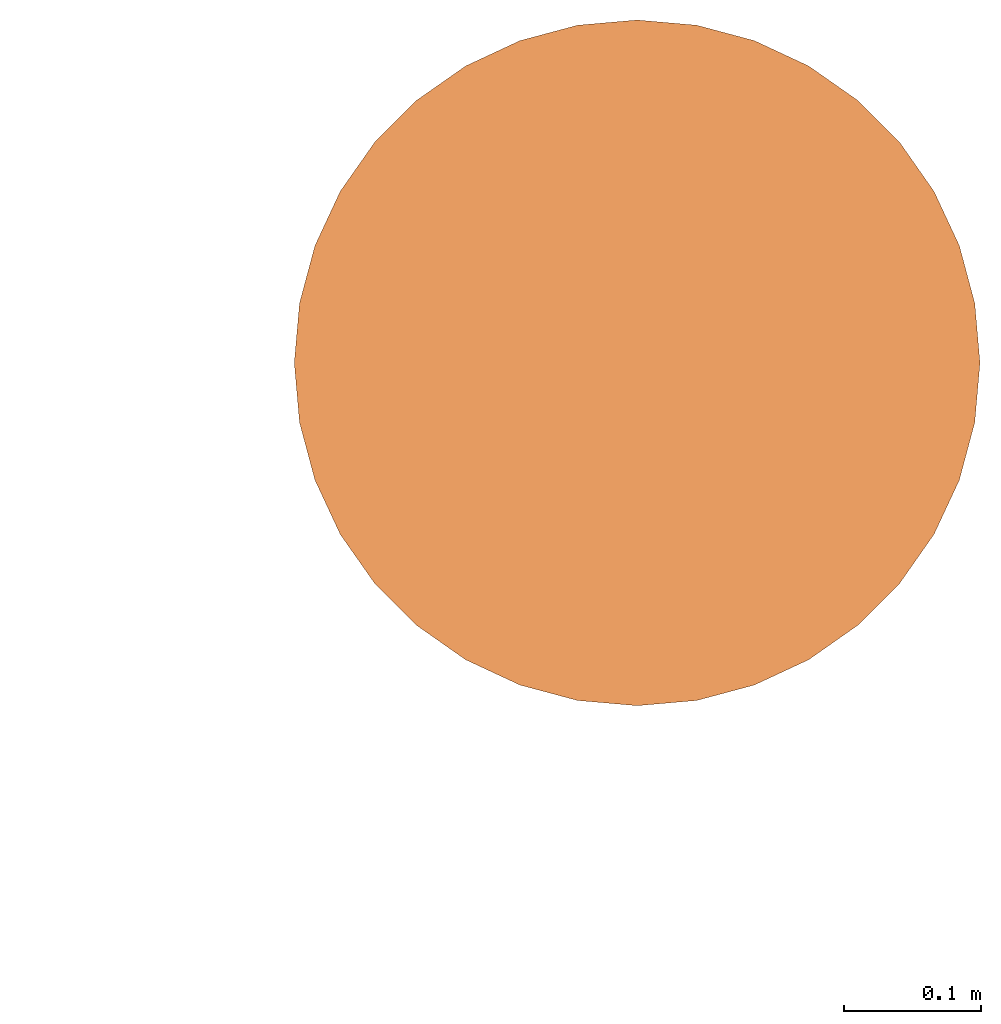
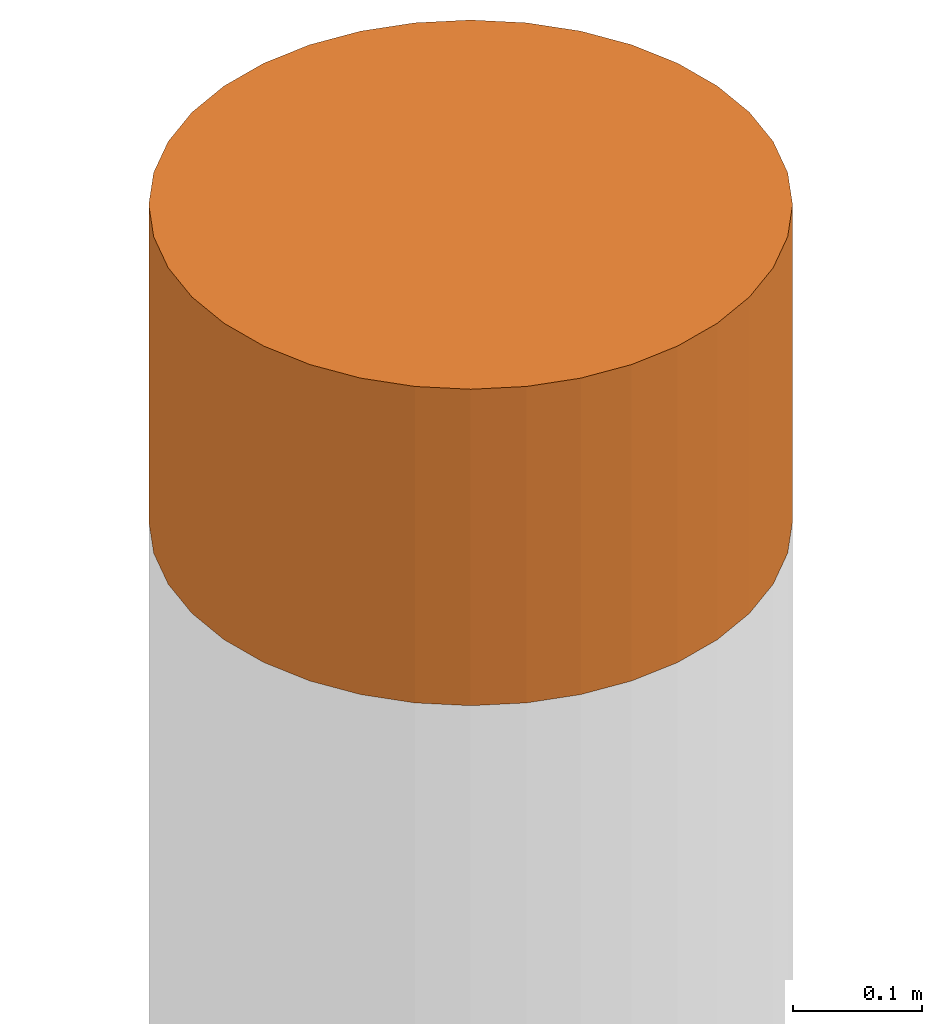
# One storey, part 8 of 8: 1 proxy.
"""IFC4 building model written with IfcOpenShell, lengths in metres."""

from ifc_helpers import new_model, entity, si_unit, converted_unit, frame, origin, place, context, subcontext, project, spatial, faceted_brep, material, element, save


model = new_model("IFC4")

# Units and contexts
model_context = context("Model", 3, precision=1e-05, world=origin())
body_context = subcontext(model_context, "Body", "Model", "MODEL_VIEW")
ifc_project = project(units=[si_unit("LENGTHUNIT", "METRE"), si_unit("AREAUNIT", "SQUARE_METRE"), si_unit("VOLUMEUNIT", "CUBIC_METRE"), converted_unit("PLANEANGLEUNIT", "DEGREE", entity("IfcPlaneAngleMeasure", 0.0174532925199433), si_unit("PLANEANGLEUNIT", "RADIAN"), dimensions=[0, 0, 0, 0, 0, 0, 0])], contexts=[model_context])

# Site, building, storey
site_placement = place(None, origin())
site = spatial("IfcSite", under=ifc_project, at=site_placement, CompositionType="ELEMENT")
building_placement = place(site_placement, origin())
building = spatial("IfcBuilding", under=site, at=building_placement, Name="Demo", CompositionType="ELEMENT")
storey_placement = place(building_placement, origin())
storey = spatial("IfcBuildingStorey", under=building, at=storey_placement, Name="Boden", CompositionType="ELEMENT", Elevation=0.0)

# Proxy
ifc_material = material()
proxy_placement = place(storey_placement, frame((15.9, 13.51, -0.09999999999999999)))
element("IfcBuildingElementProxy", 1, at=proxy_placement, inside=storey, material=ifc_material, Name="KB-03", PredefinedType="USERDEFINED", context=body_context, shape_type="Brep", body=[
    faceted_brep([(0.4962019382530489, 0.2934120444167329, 0.3), (0.5, 0.25, 0.3), (0.4962019382530489, 0.2065879555832671, 0.3), (0.4849231551964767, 0.1644949641685835, 0.3), (0.466506350946107, 0.125, 0.3), (0.441511110779742, 0.08930309757836585, 0.3), (0.4106969024216323, 0.05848888922025617, 0.3), (0.3749999999999982, 0.0334936490538912, 0.3), (0.3355050358314147, 0.01507684480352327, 0.3), (0.2934120444167311, 0.003798061746947497, 0.3), (0.2499999999999982, 0.0, 0.3), (0.2065879555832653, 0.003798061746947497, 0.3), (0.1644949641685816, 0.01507684480352327, 0.3), (0.1249999999999982, 0.03349364905388939, 0.3), (0.08930309757836404, 0.05848888922025617, 0.3), (0.05848888922025435, 0.08930309757836585, 0.3), (0.03349364905388939, 0.125, 0.3), (0.01507684480352145, 0.1644949641685835, 0.3), (0.003798061746945677, 0.2065879555832671, 0.3), (-1.818989403545857e-15, 0.25, 0.3), (0.003798061746945677, 0.2934120444167329, 0.3), (0.01507684480352145, 0.3355050358314166, 0.3), (0.03349364905388757, 0.375, 0.3), (0.05848888922025253, 0.4106969024216342, 0.3), (0.08930309757836222, 0.4415111107797439, 0.3), (0.1249999999999982, 0.4665063509461088, 0.3), (0.1644949641685798, 0.4849231551964767, 0.3), (0.2065879555832653, 0.4962019382530525, 0.3), (0.2499999999999982, 0.5, 0.3), (0.2934120444167293, 0.4962019382530525, 0.3), (0.3355050358314147, 0.4849231551964767, 0.3), (0.3749999999999982, 0.4665063509461107, 0.3), (0.4106969024216323, 0.4415111107797456, 0.3), (0.441511110779742, 0.410696902421636, 0.3), (0.466506350946107, 0.375, 0.3), (0.4849231551964767, 0.3355050358314184, 0.3), (0.5, 0.25, -1.4210854715202e-17), (0.4962019382530489, 0.2934120444167329, -1.4210854715202e-17), (0.4849231551964767, 0.3355050358314184, -1.4210854715202e-17), (0.466506350946107, 0.375, -1.4210854715202e-17), (0.441511110779742, 0.410696902421636, -1.4210854715202e-17), (0.4106969024216323, 0.4415111107797456, -1.4210854715202e-17), (0.3749999999999982, 0.4665063509461107, -1.4210854715202e-17), (0.3355050358314147, 0.4849231551964767, -1.4210854715202e-17), (0.2934120444167293, 0.4962019382530525, -1.4210854715202e-17), (0.2499999999999982, 0.5, -1.4210854715202e-17), (0.2065879555832653, 0.4962019382530525, -1.4210854715202e-17), (0.1644949641685798, 0.4849231551964767, -1.4210854715202e-17), (0.1249999999999982, 0.4665063509461088, -1.4210854715202e-17), (0.08930309757836222, 0.4415111107797439, -1.4210854715202e-17), (0.05848888922025253, 0.4106969024216342, -1.4210854715202e-17), (0.03349364905388757, 0.375, -1.4210854715202e-17), (0.01507684480352145, 0.3355050358314166, -1.4210854715202e-17), (0.003798061746945677, 0.2934120444167329, -1.4210854715202e-17), (-1.818989403545857e-15, 0.25, -1.4210854715202e-17), (0.003798061746945677, 0.2065879555832671, -1.4210854715202e-17), (0.01507684480352145, 0.1644949641685816, -1.4210854715202e-17), (0.03349364905388939, 0.125, -1.4210854715202e-17), (0.05848888922025435, 0.08930309757836585, -1.4210854715202e-17), (0.08930309757836404, 0.05848888922025617, -1.4210854715202e-17), (0.1249999999999982, 0.03349364905388939, -1.4210854715202e-17), (0.1644949641685816, 0.01507684480352327, -1.4210854715202e-17), (0.2065879555832653, 0.003798061746947497, -1.4210854715202e-17), (0.2499999999999982, 0.0, -1.4210854715202e-17), (0.2934120444167311, 0.003798061746947497, -1.4210854715202e-17), (0.3355050358314147, 0.01507684480352327, -1.4210854715202e-17), (0.3749999999999982, 0.0334936490538912, -1.4210854715202e-17), (0.4106969024216323, 0.05848888922025617, -1.4210854715202e-17), (0.441511110779742, 0.08930309757836585, -1.4210854715202e-17), (0.466506350946107, 0.125, -1.4210854715202e-17), (0.4849231551964767, 0.1644949641685835, -1.4210854715202e-17), (0.4962019382530489, 0.2065879555832671, -1.4210854715202e-17), (0.5, 0.25, 0.3), (0.4962019382530489, 0.2934120444167329, 0.3), (0.4962019382530489, 0.2934120444167329, -1.4210854715202e-17), (0.5, 0.25, -1.4210854715202e-17), (0.4962019382530489, 0.2065879555832671, 0.3), (0.5, 0.25, 0.3), (0.5, 0.25, -1.4210854715202e-17), (0.4962019382530489, 0.2065879555832671, -1.4210854715202e-17), (0.4849231551964767, 0.1644949641685835, 0.3), (0.4962019382530489, 0.2065879555832671, 0.3), (0.4962019382530489, 0.2065879555832671, -1.4210854715202e-17), (0.4849231551964767, 0.1644949641685835, -1.4210854715202e-17), (0.466506350946107, 0.125, 0.3), (0.4849231551964767, 0.1644949641685835, 0.3), (0.4849231551964767, 0.1644949641685835, -1.4210854715202e-17), (0.466506350946107, 0.125, -1.4210854715202e-17), (0.441511110779742, 0.08930309757836585, 0.3), (0.466506350946107, 0.125, 0.3), (0.466506350946107, 0.125, -1.4210854715202e-17), (0.441511110779742, 0.08930309757836585, -1.4210854715202e-17), (0.4106969024216323, 0.05848888922025617, 0.3), (0.441511110779742, 0.08930309757836585, 0.3), (0.441511110779742, 0.08930309757836585, -1.4210854715202e-17), (0.4106969024216323, 0.05848888922025617, -1.4210854715202e-17), (0.3749999999999982, 0.0334936490538912, 0.3), (0.4106969024216323, 0.05848888922025617, 0.3), (0.4106969024216323, 0.05848888922025617, -1.4210854715202e-17), (0.3749999999999982, 0.0334936490538912, -1.4210854715202e-17), (0.3355050358314147, 0.01507684480352327, 0.3), (0.3749999999999982, 0.0334936490538912, 0.3), (0.3749999999999982, 0.0334936490538912, -1.4210854715202e-17), (0.3355050358314147, 0.01507684480352327, -1.4210854715202e-17), (0.2934120444167311, 0.003798061746947497, 0.3), (0.3355050358314147, 0.01507684480352327, 0.3), (0.3355050358314147, 0.01507684480352327, -1.4210854715202e-17), (0.2934120444167311, 0.003798061746947497, -1.4210854715202e-17), (0.2499999999999982, 0.0, 0.3), (0.2934120444167311, 0.003798061746947497, 0.3), (0.2934120444167311, 0.003798061746947497, -1.4210854715202e-17), (0.2499999999999982, 0.0, -1.4210854715202e-17), (0.2065879555832653, 0.003798061746947497, 0.3), (0.2499999999999982, 0.0, 0.3), (0.2499999999999982, 0.0, -1.4210854715202e-17), (0.2065879555832653, 0.003798061746947497, -1.4210854715202e-17), (0.1644949641685816, 0.01507684480352327, 0.3), (0.2065879555832653, 0.003798061746947497, 0.3), (0.2065879555832653, 0.003798061746947497, -1.4210854715202e-17), (0.1644949641685816, 0.01507684480352327, -1.4210854715202e-17), (0.1249999999999982, 0.03349364905388939, 0.3), (0.1644949641685816, 0.01507684480352327, 0.3), (0.1644949641685816, 0.01507684480352327, -1.4210854715202e-17), (0.1249999999999982, 0.03349364905388939, -1.4210854715202e-17), (0.08930309757836404, 0.05848888922025617, 0.3), (0.1249999999999982, 0.03349364905388939, 0.3), (0.1249999999999982, 0.03349364905388939, -1.4210854715202e-17), (0.08930309757836404, 0.05848888922025617, -1.4210854715202e-17), (0.05848888922025435, 0.08930309757836585, 0.3), (0.08930309757836404, 0.05848888922025617, 0.3), (0.08930309757836404, 0.05848888922025617, -1.4210854715202e-17), (0.05848888922025435, 0.08930309757836585, -1.4210854715202e-17), (0.03349364905388939, 0.125, 0.3), (0.05848888922025435, 0.08930309757836585, 0.3), (0.05848888922025435, 0.08930309757836585, -1.4210854715202e-17), (0.03349364905388939, 0.125, -1.4210854715202e-17), (0.01507684480352145, 0.1644949641685835, 0.3), (0.03349364905388939, 0.125, 0.3), (0.03349364905388939, 0.125, -1.4210854715202e-17), (0.01507684480352145, 0.1644949641685816, -1.4210854715202e-17), (0.003798061746945677, 0.2065879555832671, 0.3), (0.01507684480352145, 0.1644949641685835, 0.3), (0.01507684480352145, 0.1644949641685816, -1.4210854715202e-17), (0.003798061746945677, 0.2065879555832671, -1.4210854715202e-17), (-1.818989403545857e-15, 0.25, 0.3), (0.003798061746945677, 0.2065879555832671, 0.3), (0.003798061746945677, 0.2065879555832671, -1.4210854715202e-17), (-1.818989403545857e-15, 0.25, -1.4210854715202e-17), (0.003798061746945677, 0.2934120444167329, 0.3), (-1.818989403545857e-15, 0.25, 0.3), (-1.818989403545857e-15, 0.25, -1.4210854715202e-17), (0.003798061746945677, 0.2934120444167329, -1.4210854715202e-17), (0.01507684480352145, 0.3355050358314166, 0.3), (0.003798061746945677, 0.2934120444167329, 0.3), (0.003798061746945677, 0.2934120444167329, -1.4210854715202e-17), (0.01507684480352145, 0.3355050358314166, -1.4210854715202e-17), (0.03349364905388757, 0.375, 0.3), (0.01507684480352145, 0.3355050358314166, 0.3), (0.01507684480352145, 0.3355050358314166, -1.4210854715202e-17), (0.03349364905388757, 0.375, -1.4210854715202e-17), (0.05848888922025253, 0.4106969024216342, 0.3), (0.03349364905388757, 0.375, 0.3), (0.03349364905388757, 0.375, -1.4210854715202e-17), (0.05848888922025253, 0.4106969024216342, -1.4210854715202e-17), (0.08930309757836222, 0.4415111107797439, 0.3), (0.05848888922025253, 0.4106969024216342, 0.3), (0.05848888922025253, 0.4106969024216342, -1.4210854715202e-17), (0.08930309757836222, 0.4415111107797439, -1.4210854715202e-17), (0.1249999999999982, 0.4665063509461088, 0.3), (0.08930309757836222, 0.4415111107797439, 0.3), (0.08930309757836222, 0.4415111107797439, -1.4210854715202e-17), (0.1249999999999982, 0.4665063509461088, -1.4210854715202e-17), (0.1644949641685798, 0.4849231551964767, 0.3), (0.1249999999999982, 0.4665063509461088, 0.3), (0.1249999999999982, 0.4665063509461088, -1.4210854715202e-17), (0.1644949641685798, 0.4849231551964767, -1.4210854715202e-17), (0.2065879555832653, 0.4962019382530525, 0.3), (0.1644949641685798, 0.4849231551964767, 0.3), (0.1644949641685798, 0.4849231551964767, -1.4210854715202e-17), (0.2065879555832653, 0.4962019382530525, -1.4210854715202e-17), (0.2499999999999982, 0.5, 0.3), (0.2065879555832653, 0.4962019382530525, 0.3), (0.2065879555832653, 0.4962019382530525, -1.4210854715202e-17), (0.2499999999999982, 0.5, -1.4210854715202e-17), (0.2934120444167293, 0.4962019382530525, 0.3), (0.2499999999999982, 0.5, 0.3), (0.2499999999999982, 0.5, -1.4210854715202e-17), (0.2934120444167293, 0.4962019382530525, -1.4210854715202e-17), (0.3355050358314147, 0.4849231551964767, 0.3), (0.2934120444167293, 0.4962019382530525, 0.3), (0.2934120444167293, 0.4962019382530525, -1.4210854715202e-17), (0.3355050358314147, 0.4849231551964767, -1.4210854715202e-17), (0.3749999999999982, 0.4665063509461107, 0.3), (0.3355050358314147, 0.4849231551964767, 0.3), (0.3355050358314147, 0.4849231551964767, -1.4210854715202e-17), (0.3749999999999982, 0.4665063509461107, -1.4210854715202e-17), (0.4106969024216323, 0.4415111107797456, 0.3), (0.3749999999999982, 0.4665063509461107, 0.3), (0.3749999999999982, 0.4665063509461107, -1.4210854715202e-17), (0.4106969024216323, 0.4415111107797456, -1.4210854715202e-17), (0.441511110779742, 0.410696902421636, 0.3), (0.4106969024216323, 0.4415111107797456, 0.3), (0.4106969024216323, 0.4415111107797456, -1.4210854715202e-17), (0.441511110779742, 0.410696902421636, -1.4210854715202e-17), (0.466506350946107, 0.375, 0.3), (0.441511110779742, 0.410696902421636, 0.3), (0.441511110779742, 0.410696902421636, -1.4210854715202e-17), (0.466506350946107, 0.375, -1.4210854715202e-17), (0.4849231551964767, 0.3355050358314184, 0.3), (0.466506350946107, 0.375, 0.3), (0.466506350946107, 0.375, -1.4210854715202e-17), (0.4849231551964767, 0.3355050358314184, -1.4210854715202e-17), (0.4962019382530489, 0.2934120444167329, 0.3), (0.4849231551964767, 0.3355050358314184, 0.3), (0.4849231551964767, 0.3355050358314184, -1.4210854715202e-17), (0.4962019382530489, 0.2934120444167329, -1.4210854715202e-17)], [[[0, 1, 2, 3, 4, 5, 6, 7, 8, 9, 10, 11, 12, 13, 14, 15, 16, 17, 18, 19, 20, 21, 22, 23, 24, 25, 26, 27, 28, 29, 30, 31, 32, 33, 34, 35]], [[36, 37, 38, 39, 40, 41, 42, 43, 44, 45, 46, 47, 48, 49, 50, 51, 52, 53, 54, 55, 56, 57, 58, 59, 60, 61, 62, 63, 64, 65, 66, 67, 68, 69, 70, 71]], [[72, 73, 74, 75]], [[76, 77, 78, 79]], [[80, 81, 82, 83]], [[84, 85, 86, 87]], [[88, 89, 90, 91]], [[92, 93, 94, 95]], [[96, 97, 98, 99]], [[100, 101, 102, 103]], [[104, 105, 106, 107]], [[108, 109, 110, 111]], [[112, 113, 114, 115]], [[116, 117, 118, 119]], [[120, 121, 122, 123]], [[124, 125, 126, 127]], [[128, 129, 130, 131]], [[132, 133, 134, 135]], [[136, 137, 138, 139]], [[140, 141, 142, 143]], [[144, 145, 146, 147]], [[148, 149, 150, 151]], [[152, 153, 154, 155]], [[156, 157, 158, 159]], [[160, 161, 162, 163]], [[164, 165, 166, 167]], [[168, 169, 170, 171]], [[172, 173, 174, 175]], [[176, 177, 178, 179]], [[180, 181, 182, 183]], [[184, 185, 186, 187]], [[188, 189, 190, 191]], [[192, 193, 194, 195]], [[196, 197, 198, 199]], [[200, 201, 202, 203]], [[204, 205, 206, 207]], [[208, 209, 210, 211]], [[212, 213, 214, 215]]], orient=[[False], [False], [False], [False], [False], [False], [False], [False], [False], [False], [False], [False], [False], [False], [False], [False], [False], [False], [False], [False], [False], [False], [False], [False], [False], [False], [False], [False], [False], [False], [False], [False], [False], [False], [False], [False], [False], [False]]),
])

save(model, "model.ifc")
